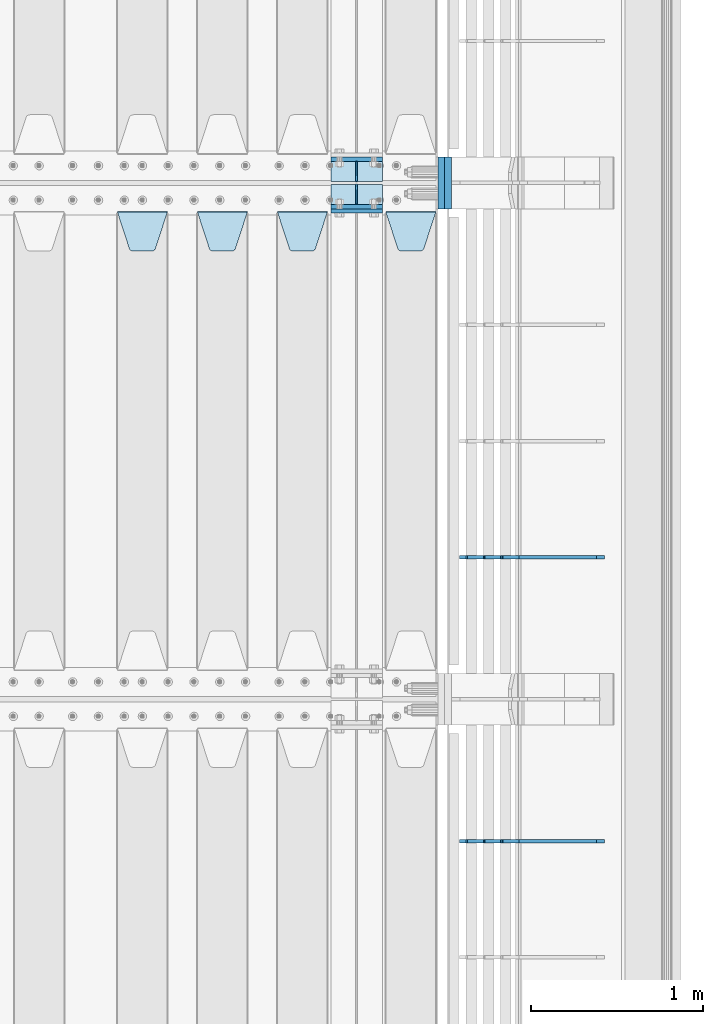
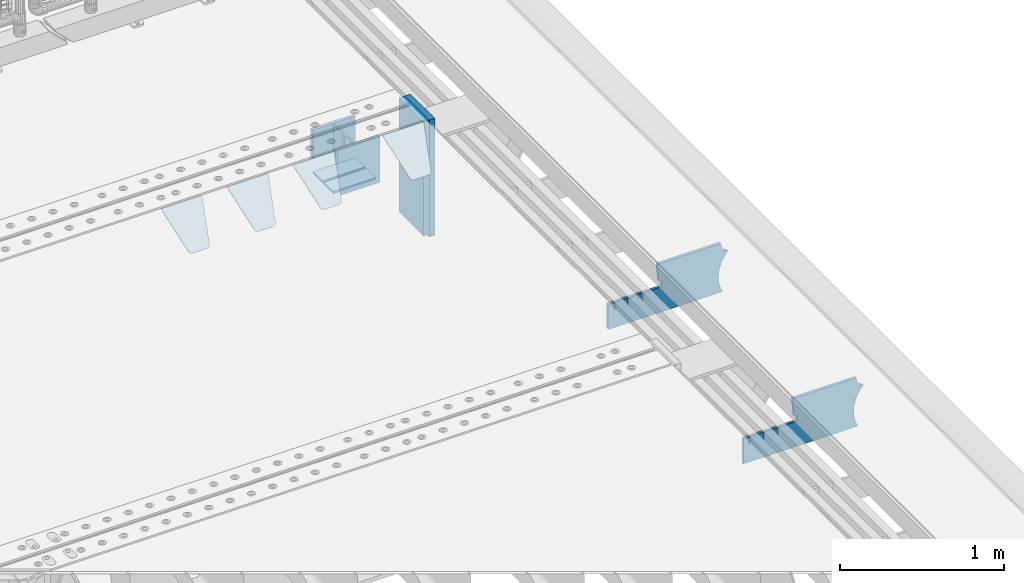
# One storey, part 239 of 257: 15 plates.
"""IFC2X3 building model written with IfcOpenShell, lengths in millimetres."""

from ifc_helpers import new_model, si_unit, frame, origin_with_axes, place, context, subcontext, project, spatial, faceted_brep, material, type_object, element, save


model = new_model("IFC2X3")

# Units and contexts
model_context = context("Model", 3, precision=1e-05, world=origin_with_axes())
body_context = subcontext(model_context, "Body", "Model", "MODEL_VIEW")
ifc_project = project(units=[si_unit("LENGTHUNIT", "METRE", prefix="MILLI"), si_unit("AREAUNIT", "SQUARE_METRE"), si_unit("VOLUMEUNIT", "CUBIC_METRE"), si_unit("MASSUNIT", "GRAM", prefix="KILO"), si_unit("TIMEUNIT", "SECOND"), si_unit("PLANEANGLEUNIT", "RADIAN"), si_unit("SOLIDANGLEUNIT", "STERADIAN"), si_unit("THERMODYNAMICTEMPERATUREUNIT", "DEGREE_CELSIUS"), si_unit("LUMINOUSINTENSITYUNIT", "LUMEN")], contexts=[model_context])

# Site, building, storey
site_placement = place(None, origin_with_axes())
site = spatial("IfcSite", under=ifc_project, at=site_placement, CompositionType="ELEMENT")
building_placement = place(site_placement, origin_with_axes())
building = spatial("IfcBuilding", under=site, at=building_placement, Name="Standard", CompositionType="ELEMENT")
storey_placement = place(building_placement, origin_with_axes())
storey = spatial("IfcBuildingStorey", under=building, at=storey_placement, Name="Undefined", CompositionType="ELEMENT", Elevation=0.0)

# Plates
ifc_material_1 = material(Name="STEEL/S355N")
plate_type_1 = type_object("IfcPlateType", PredefinedType="NOTDEFINED")
for number, where, z_axis, x_axis in (
    (1, (58645.0, 9137.49999999999, -339.999999999993), (0.0, 0.0, 1.0), (1.0, 0.0, 0.0)),
    (2, (58645.0, 8862.49999999999, -339.999999999993), (0.0, 0.0, 1.0), (1.0, 0.0, 0.0)),
):
    element("IfcPlate", number, at=place(storey_placement, frame(where, z_axis=z_axis, x_axis=x_axis)), inside=storey, type_object=plate_type_1, material=ifc_material_1, context=body_context, shape_type="Brep", body=[
        faceted_brep([(0.0, -12.5, 0.0), (0.0, -12.5, 310.0), (0.0, 12.5, 310.0), (0.0, 12.5, 0.0), (300.0, -12.5, 310.0), (300.0, 12.5, 310.0), (300.0, -12.5, 0.0), (300.0, 12.5, 0.0)], [[[0, 1, 2, 3]], [[1, 4, 5, 2]], [[4, 6, 7, 5]], [[6, 0, 3, 7]], [[5, 7, 3, 2]], [[6, 4, 1, 0]]]),
    ])
plate_1_placement = place(storey_placement, frame((58645.0, 8837.5, -340.000000000044), z_axis=(0.0, 0.0, 1.0), x_axis=(1.0, 0.0, 0.0)))
element("IfcPlate", 3, at=plate_1_placement, inside=storey, type_object=plate_type_1, material=ifc_material_1, context=body_context, shape_type="Brep", body=[
    faceted_brep([(0.0, -12.5, 0.0), (0.0, -12.5, 340.0), (0.0, 12.5, 340.0), (0.0, 12.5, 0.0), (300.0, -12.5, 340.0), (300.0, 12.5, 340.0), (300.0, -12.5, 0.0), (300.0, 12.5, 0.0)], [[[0, 1, 2, 3]], [[1, 4, 5, 2]], [[4, 6, 7, 5]], [[6, 0, 3, 7]], [[5, 7, 3, 2]], [[6, 4, 1, 0]]]),
])
plate_type_2 = type_object("IfcPlateType", PredefinedType="NOTDEFINED")
for number, where, z_axis, x_axis in (
    (4, (58645.0, 8991.99999999999, -342.999999999993), (0.0, -1.0, 0.0), (1.0, 0.0, 0.0)),
    (5, (58645.0, 9007.99999999999, -342.999999999993), (0.0, 1.0, 0.0), (1.0, 0.0, 0.0)),
):
    element("IfcPlate", number, at=place(storey_placement, frame(where, z_axis=z_axis, x_axis=x_axis)), inside=storey, type_object=plate_type_2, material=ifc_material_1, context=body_context, shape_type="Brep", body=[
        faceted_brep([(0.0, -7.0, 0.0), (0.0, -7.0, 117.0), (0.0, 7.0, 117.0), (0.0, 7.0, 0.0), (300.0, -7.0, 117.0), (300.0, 7.0, 117.0), (300.0, -7.0, 0.0), (300.0, 7.0, 0.0)], [[[0, 1, 2, 3]], [[1, 4, 5, 2]], [[4, 6, 7, 5]], [[6, 0, 3, 7]], [[5, 7, 3, 2]], [[6, 4, 1, 0]]]),
    ])
plate_type_3 = type_object("IfcPlateType", PredefinedType="NOTDEFINED")
for number, where, z_axis, x_axis in (
    (6, (58795.0, 9007.99999999999, -29.999999999993), (0.0, 0.0, -1.0), (0.0, 1.0, 0.0)),
    (7, (58795.0, 8991.99999999999, -29.999999999993), (0.0, 0.0, -1.0), (0.0, -1.0, 0.0)),
):
    element("IfcPlate", number, at=place(storey_placement, frame(where, z_axis=z_axis, x_axis=x_axis)), inside=storey, type_object=plate_type_3, material=ifc_material_1, context=body_context, shape_type="Brep", body=[
        faceted_brep([(0.0, -5.0, 30.0), (0.0, -5.0, 306.0), (0.0, 5.0, 306.0), (0.0, 5.0, 30.0), (117.0, -5.0, 306.0), (117.0, 5.0, 306.0), (117.0, -5.0, 0.0), (117.0, 5.0, 0.0), (30.0, -5.0, 0.0), (30.0, 5.0, 0.0), (24.7905546699922, -5.0, 0.455767409633758), (24.7905546699922, 5.0, 0.455767409633758), (19.7393957002296, -5.0, 1.80922137642275), (19.7393957002296, 5.0, 1.80922137642275), (15.0, -5.0, 4.01923788646684), (15.0, 5.0, 4.01923788646684), (10.7163717094036, -5.0, 7.01866670643066), (10.7163717094036, 5.0, 7.01866670643066), (7.01866670643085, -5.0, 10.7163717094038), (7.01866670643085, 5.0, 10.7163717094038), (4.01923788646673, -5.0, 15.0), (4.01923788646673, 5.0, 15.0), (1.80922137642301, -5.0, 19.7393957002299), (1.80922137642301, 5.0, 19.7393957002299), (0.455767409634063, -5.0, 24.7905546699921), (0.455767409634063, 5.0, 24.7905546699921)], [[[0, 1, 2, 3]], [[1, 4, 5, 2]], [[4, 6, 7, 5]], [[6, 8, 9, 7]], [[8, 10, 11, 9]], [[10, 12, 13, 11]], [[12, 14, 15, 13]], [[14, 16, 17, 15]], [[16, 18, 19, 17]], [[18, 20, 21, 19]], [[20, 22, 23, 21]], [[22, 24, 25, 23]], [[24, 0, 3, 25]], [[5, 7, 9, 11, 13, 15, 17, 19, 21, 23, 25, 3, 2]], [[24, 22, 20, 18, 16, 14, 12, 10, 8, 6, 4, 1, 0]]]),
    ])
plate_type_4 = type_object("IfcPlateType", PredefinedType="NOTDEFINED")
plate_2_placement = place(storey_placement, frame((58965.0, 8831.76776695594, -1.767766952965), z_axis=(0.0, -0.707106781186548, -0.707106781186547), x_axis=(1.0, 0.0, 0.0)))
element("IfcPlate", 8, at=plate_2_placement, inside=storey, type_object=plate_type_4, material=ifc_material_1, context=body_context, shape_type="Brep", body=[
    faceted_brep([(0.0, -2.5, 0.0), (69.345504679477, -2.50000000000091, 300.17173142483), (69.345504679477, 2.5, 300.171731424831), (0.0, 2.5, 0.0), (70.927406119954, -2.50000000000091, 304.8974424154), (70.927406119954, 2.5, 304.8974424154), (73.3818627772271, -2.50000000000091, 309.234538108527), (73.3818627772271, 2.49999999999909, 309.234538108527), (76.6187032999587, -2.5, 313.023683126103), (76.6187032999587, 2.5, 313.023683126103), (80.5190132705029, -2.5, 316.125672595372), (80.5190132705029, 2.5, 316.125672595371), (84.9395038596849, -2.5, 318.426546230476), (84.9395038596849, 2.5, 318.426546230477), (89.7177759439219, -2.5, 319.841774983275), (89.7177759439219, 2.5, 319.841774983275), (94.6782862926484, -2.5, 320.319366455079), (94.6782862926484, 2.5, 320.319366455079), (195.321713707352, -2.5, 320.319366455079), (195.321713707352, 2.5, 320.319366455079), (200.282224056078, -2.5, 319.841774983275), (200.282224056078, 2.49999999999909, 319.841774983275), (205.060496140315, -2.5, 318.426546230476), (205.060496140315, 2.49999999999909, 318.426546230475), (209.480986729497, -2.5, 316.125672595371), (209.480986729497, 2.5, 316.125672595371), (213.381296700041, -2.50000000000091, 313.023683126102), (213.381296700041, 2.5, 313.023683126103), (216.618137222766, -2.50000000000091, 309.234538108527), (216.618137222766, 2.5, 309.234538108527), (219.072593880039, -2.5, 304.897442415399), (219.072593880039, 2.5, 304.897442415399), (220.654495320523, -2.50000000000091, 300.17173142483), (220.654495320523, 2.5, 300.171731424831), (290.0, -2.50000000000091, 0.0), (290.0, 2.5, 9.09494701772928e-13)], [[[0, 1, 2, 3]], [[1, 4, 5, 2]], [[4, 6, 7, 5]], [[6, 8, 9, 7]], [[8, 10, 11, 9]], [[10, 12, 13, 11]], [[12, 14, 15, 13]], [[14, 16, 17, 15]], [[16, 18, 19, 17]], [[18, 20, 21, 19]], [[20, 22, 23, 21]], [[22, 24, 25, 23]], [[24, 26, 27, 25]], [[26, 28, 29, 27]], [[28, 30, 31, 29]], [[30, 32, 33, 31]], [[32, 34, 35, 33]], [[34, 0, 3, 35]], [[5, 7, 9, 11, 13, 15, 17, 19, 21, 23, 25, 27, 29, 31, 33, 35, 3, 2]], [[34, 32, 30, 28, 26, 24, 22, 20, 18, 16, 14, 12, 10, 8, 6, 4, 1, 0]]]),
])
plate_3_placement = place(storey_placement, frame((58335.0, 8831.76776695594, -1.767766952965), z_axis=(0.0, -0.707106781186548, -0.707106781186547), x_axis=(1.0, 0.0, 0.0)))
element("IfcPlate", 9, at=plate_3_placement, inside=storey, type_object=plate_type_4, material=ifc_material_1, context=body_context, shape_type="Brep", body=[
    faceted_brep([(0.0, -2.5, 0.0), (69.345504679477, -2.50000000000091, 300.17173142483), (69.345504679477, 2.5, 300.171731424831), (0.0, 2.5, 0.0), (70.927406119954, -2.50000000000091, 304.8974424154), (70.927406119954, 2.5, 304.8974424154), (73.3818627772271, -2.50000000000091, 309.234538108527), (73.3818627772271, 2.49999999999909, 309.234538108527), (76.6187032999587, -2.5, 313.023683126103), (76.6187032999587, 2.5, 313.023683126103), (80.5190132705029, -2.5, 316.125672595372), (80.5190132705029, 2.5, 316.125672595371), (84.9395038596849, -2.5, 318.426546230476), (84.9395038596849, 2.5, 318.426546230477), (89.7177759439219, -2.5, 319.841774983275), (89.7177759439219, 2.5, 319.841774983275), (94.6782862926484, -2.5, 320.319366455079), (94.6782862926484, 2.5, 320.319366455079), (195.321713707352, -2.5, 320.319366455079), (195.321713707352, 2.5, 320.319366455079), (200.282224056078, -2.5, 319.841774983275), (200.282224056078, 2.49999999999909, 319.841774983275), (205.060496140315, -2.5, 318.426546230476), (205.060496140315, 2.49999999999909, 318.426546230475), (209.480986729497, -2.5, 316.125672595371), (209.480986729497, 2.5, 316.125672595371), (213.381296700041, -2.50000000000091, 313.023683126102), (213.381296700041, 2.5, 313.023683126103), (216.618137222766, -2.50000000000091, 309.234538108527), (216.618137222766, 2.5, 309.234538108527), (219.072593880039, -2.5, 304.897442415399), (219.072593880039, 2.5, 304.897442415399), (220.654495320523, -2.50000000000091, 300.17173142483), (220.654495320523, 2.5, 300.171731424831), (290.0, -2.50000000000091, 0.0), (290.0, 2.5, 9.09494701772928e-13)], [[[0, 1, 2, 3]], [[1, 4, 5, 2]], [[4, 6, 7, 5]], [[6, 8, 9, 7]], [[8, 10, 11, 9]], [[10, 12, 13, 11]], [[12, 14, 15, 13]], [[14, 16, 17, 15]], [[16, 18, 19, 17]], [[18, 20, 21, 19]], [[20, 22, 23, 21]], [[22, 24, 25, 23]], [[24, 26, 27, 25]], [[26, 28, 29, 27]], [[28, 30, 31, 29]], [[30, 32, 33, 31]], [[32, 34, 35, 33]], [[34, 0, 3, 35]], [[5, 7, 9, 11, 13, 15, 17, 19, 21, 23, 25, 27, 29, 31, 33, 35, 3, 2]], [[34, 32, 30, 28, 26, 24, 22, 20, 18, 16, 14, 12, 10, 8, 6, 4, 1, 0]]]),
])
plate_4_placement = place(storey_placement, frame((57870.0, 8831.76776695594, -1.767766952965), z_axis=(0.0, -0.707106781186548, -0.707106781186547), x_axis=(1.0, 0.0, 0.0)))
element("IfcPlate", 10, at=plate_4_placement, inside=storey, type_object=plate_type_4, material=ifc_material_1, context=body_context, shape_type="Brep", body=[
    faceted_brep([(0.0, -2.5, 0.0), (69.345504679477, -2.50000000000091, 300.17173142483), (69.345504679477, 2.5, 300.171731424831), (0.0, 2.5, 0.0), (70.927406119954, -2.50000000000091, 304.8974424154), (70.927406119954, 2.5, 304.8974424154), (73.3818627772271, -2.50000000000091, 309.234538108527), (73.3818627772271, 2.49999999999909, 309.234538108527), (76.6187032999587, -2.5, 313.023683126103), (76.6187032999587, 2.5, 313.023683126103), (80.5190132705029, -2.5, 316.125672595372), (80.5190132705029, 2.5, 316.125672595371), (84.9395038596849, -2.5, 318.426546230476), (84.9395038596849, 2.5, 318.426546230477), (89.7177759439219, -2.5, 319.841774983275), (89.7177759439219, 2.5, 319.841774983275), (94.6782862926484, -2.5, 320.319366455079), (94.6782862926484, 2.5, 320.319366455079), (195.321713707352, -2.5, 320.319366455079), (195.321713707352, 2.5, 320.319366455079), (200.282224056078, -2.5, 319.841774983275), (200.282224056078, 2.49999999999909, 319.841774983275), (205.060496140315, -2.5, 318.426546230476), (205.060496140315, 2.49999999999909, 318.426546230475), (209.480986729497, -2.5, 316.125672595371), (209.480986729497, 2.5, 316.125672595371), (213.381296700041, -2.50000000000091, 313.023683126102), (213.381296700041, 2.5, 313.023683126103), (216.618137222766, -2.50000000000091, 309.234538108527), (216.618137222766, 2.5, 309.234538108527), (219.072593880039, -2.5, 304.897442415399), (219.072593880039, 2.5, 304.897442415399), (220.654495320523, -2.50000000000091, 300.17173142483), (220.654495320523, 2.5, 300.171731424831), (290.0, -2.50000000000091, 0.0), (290.0, 2.5, 9.09494701772928e-13)], [[[0, 1, 2, 3]], [[1, 4, 5, 2]], [[4, 6, 7, 5]], [[6, 8, 9, 7]], [[8, 10, 11, 9]], [[10, 12, 13, 11]], [[12, 14, 15, 13]], [[14, 16, 17, 15]], [[16, 18, 19, 17]], [[18, 20, 21, 19]], [[20, 22, 23, 21]], [[22, 24, 25, 23]], [[24, 26, 27, 25]], [[26, 28, 29, 27]], [[28, 30, 31, 29]], [[30, 32, 33, 31]], [[32, 34, 35, 33]], [[34, 0, 3, 35]], [[5, 7, 9, 11, 13, 15, 17, 19, 21, 23, 25, 27, 29, 31, 33, 35, 3, 2]], [[34, 32, 30, 28, 26, 24, 22, 20, 18, 16, 14, 12, 10, 8, 6, 4, 1, 0]]]),
])
plate_5_placement = place(storey_placement, frame((57405.0, 8831.76776695594, -1.767766952965), z_axis=(0.0, -0.707106781186548, -0.707106781186547), x_axis=(1.0, 0.0, 0.0)))
element("IfcPlate", 11, at=plate_5_placement, inside=storey, type_object=plate_type_4, material=ifc_material_1, context=body_context, shape_type="Brep", body=[
    faceted_brep([(0.0, -2.5, 0.0), (69.345504679477, -2.50000000000091, 300.17173142483), (69.345504679477, 2.5, 300.171731424831), (0.0, 2.5, 0.0), (70.927406119954, -2.50000000000091, 304.8974424154), (70.927406119954, 2.5, 304.8974424154), (73.3818627772271, -2.50000000000091, 309.234538108527), (73.3818627772271, 2.49999999999909, 309.234538108527), (76.6187032999587, -2.5, 313.023683126103), (76.6187032999587, 2.5, 313.023683126103), (80.5190132705029, -2.5, 316.125672595372), (80.5190132705029, 2.5, 316.125672595371), (84.9395038596849, -2.5, 318.426546230476), (84.9395038596849, 2.5, 318.426546230477), (89.7177759439219, -2.5, 319.841774983275), (89.7177759439219, 2.5, 319.841774983275), (94.6782862926484, -2.5, 320.319366455079), (94.6782862926484, 2.5, 320.319366455079), (195.321713707352, -2.5, 320.319366455079), (195.321713707352, 2.5, 320.319366455079), (200.282224056078, -2.5, 319.841774983275), (200.282224056078, 2.49999999999909, 319.841774983275), (205.060496140315, -2.5, 318.426546230476), (205.060496140315, 2.49999999999909, 318.426546230475), (209.480986729497, -2.5, 316.125672595371), (209.480986729497, 2.5, 316.125672595371), (213.381296700041, -2.50000000000091, 313.023683126102), (213.381296700041, 2.5, 313.023683126103), (216.618137222766, -2.50000000000091, 309.234538108527), (216.618137222766, 2.5, 309.234538108527), (219.072593880039, -2.5, 304.897442415399), (219.072593880039, 2.5, 304.897442415399), (220.654495320523, -2.50000000000091, 300.17173142483), (220.654495320523, 2.5, 300.171731424831), (290.0, -2.50000000000091, 0.0), (290.0, 2.5, 9.09494701772928e-13)], [[[0, 1, 2, 3]], [[1, 4, 5, 2]], [[4, 6, 7, 5]], [[6, 8, 9, 7]], [[8, 10, 11, 9]], [[10, 12, 13, 11]], [[12, 14, 15, 13]], [[14, 16, 17, 15]], [[16, 18, 19, 17]], [[18, 20, 21, 19]], [[20, 22, 23, 21]], [[22, 24, 25, 23]], [[24, 26, 27, 25]], [[26, 28, 29, 27]], [[28, 30, 31, 29]], [[30, 32, 33, 31]], [[32, 34, 35, 33]], [[34, 0, 3, 35]], [[5, 7, 9, 11, 13, 15, 17, 19, 21, 23, 25, 27, 29, 31, 33, 35, 3, 2]], [[34, 32, 30, 28, 26, 24, 22, 20, 18, 16, 14, 12, 10, 8, 6, 4, 1, 0]]]),
])
ifc_material_2 = material()
plate_type_5 = type_object("IfcPlateType", PredefinedType="NOTDEFINED")
plate_6_placement = place(storey_placement, frame((59287.0, 9150.0, -870.0), z_axis=(0.0, 0.0, 1.0), x_axis=(0.0, -1.0, 0.0)))
element("IfcPlate", 12, at=plate_6_placement, inside=storey, type_object=plate_type_5, material=ifc_material_2, context=body_context, shape_type="Brep", body=[
    faceted_brep([(0.0, -20.0, 0.0), (0.0, -20.0, 850.0), (0.0, 20.0, 850.0), (0.0, 20.0, 0.0), (300.0, -20.0, 850.0), (300.0, 20.0, 850.0), (300.0, -20.0, -1.81898940354586e-12), (300.0, 20.0, -1.81898940354586e-12)], [[[0, 1, 2, 3]], [[1, 4, 5, 2]], [[4, 6, 7, 5]], [[6, 0, 3, 7]], [[5, 7, 3, 2]], [[6, 4, 1, 0]]]),
])
plate_7_placement = place(storey_placement, frame((59326.9988298906, 9150.0, -889.999999999995), z_axis=(0.0, 0.0, 1.0), x_axis=(0.0, -1.0, 0.0)))
element("IfcPlate", 13, at=plate_7_placement, inside=storey, type_object=plate_type_5, material=ifc_material_2, context=body_context, shape_type="Brep", body=[
    faceted_brep([(0.0, -20.0, 0.0), (0.0, -20.0, 870.0), (0.0, 20.0, 870.0), (0.0, 20.0, 0.0), (300.0, -20.0, 870.0), (300.0, 20.0, 870.0), (300.0, -20.0, -1.81898940354586e-12), (300.0, 20.0, -1.81898940354586e-12)], [[[0, 1, 2, 3]], [[1, 4, 5, 2]], [[4, 6, 7, 5]], [[6, 0, 3, 7]], [[5, 7, 3, 2]], [[6, 4, 1, 0]]]),
])
plate_type_6 = type_object("IfcPlateType", PredefinedType="NOTDEFINED")
plate_8_placement = place(storey_placement, frame((60232.9182339676, 5174.99928283691, -374.002067436517), z_axis=(0.0, 0.0, 1.0), x_axis=(-1.0, 0.0, 0.0)))
element("IfcPlate", 14, at=plate_8_placement, inside=storey, type_object=plate_type_6, material=ifc_material_1, context=body_context, shape_type="Brep", body=[
    faceted_brep([(801.919404066546, -10.0, 188.0), (801.919404066546, 10.0, 188.0), (801.919404066546, 10.0, 132.002067436952), (801.919404066546, -10.0, 132.002067436952), (793.919404066546, 10.0, 132.002067436952), (793.919404066546, -10.0, 132.002067436952), (793.919404066546, 10.0, 180.002067436952), (793.919404066546, -10.0, 180.002067436952), (793.52785619691, 10.0, 182.474203391951), (793.52785619691, -10.0, 182.474203391951), (792.391540021548, 10.0, 184.704349455291), (792.391540021548, -10.0, 184.704349455291), (790.621686084887, 10.0, 186.474203391951), (790.621686084887, -10.0, 186.474203391951), (788.391540021548, 10.0, 187.610519567313), (788.391540021548, -10.0, 187.610519567313), (785.919404066546, -10.0, 188.002067436952), (785.919404066546, 10.0, 188.0), (841.0, -10.0, 188.0), (841.0, -10.0, 0.0), (841.0, 10.0, 0.0), (841.0, 10.0, 188.0), (33.3619566735943, -10.0, 0.0), (33.3619566735943, 10.0, 0.0), (36.2350612208102, -10.0, 4.68848050267013), (36.2350612208102, 10.0, 4.68848050267013), (51.4877592159319, -10.0, 41.5117508652784), (51.4877592159319, 10.0, 41.5117508652784), (60.7922425881334, -10.0, 80.2677133162964), (60.7922425881334, 10.0, 80.2677133162964), (63.9194040769653, -10.0, 120.002067436515), (63.9194040769653, 10.0, 120.002067436515), (60.7922425881334, -10.0, 159.736421556734), (60.7922425881334, 10.0, 159.736421556734), (51.4877592159319, -10.0, 198.492384007752), (51.4877592159319, 10.0, 198.492384007752), (36.2350612208102, -10.0, 235.31565437036), (36.2350612208102, 10.0, 235.31565437036), (15.4097206482038, -10.0, 269.299521518803), (15.4097206482038, 10.0, 269.299521518803), (-3.35474438100209, -10.0, 291.269887256574), (-3.35474438100209, 10.0, 291.269887256574), (-2.36881039375294, -10.0000000000001, 291.426043859339), (-2.36881039375294, 10.0, 291.426043859339), (17.1449676604752, -10.0000000000001, 301.368810393754), (17.1449676604752, 10.0, 301.368810393754), (32.6311896062471, -10.0000000000001, 316.855032339527), (32.6311896062471, 10.0, 316.855032339527), (42.573956140659, -10.0000000000001, 336.368810393754), (42.573956140659, 10.0, 336.368810393754), (46.0, -10.0000000000001, 358.0), (46.0, 10.0, 358.0), (45.0495205499174, -10.0, 364.001091067617), (45.0495205499174, 10.0, 364.001091067617), (495.040008544922, -10.0, 364.010009765625), (495.040008544922, 10.0, 364.010009765625), (483.600036621094, -10.0, 233.759994506836), (483.600036621094, 10.0, 233.759994506836), (472.0, -10.0, 233.759994506836), (472.0, 10.0, 233.759994506836), (468.909830056247, -10.0, 233.270559669787), (468.909830056247, 10.0, 233.270559669787), (466.122147477072, -10.0, 231.850164450585), (466.122147477072, 10.0, 231.850164450585), (463.909830056247, -10.0, 229.637847029761), (463.909830056247, 10.0, 229.637847029761), (462.489434837051, -10.0, 226.850164450585), (462.489434837051, 10.0, 226.850164450585), (462.0, -10.0, 223.759994506836), (462.0, 10.0, 223.759994506836), (462.0, -10.0, 198.0), (462.0, 10.0, 198.0), (462.489434837051, -10.0, 194.909830056251), (462.489434837051, 10.0, 194.909830056251), (463.909830056247, -10.0, 192.122147477075), (463.909830056247, 10.0, 192.122147477075), (466.122147477072, -10.0, 189.909830056251), (466.122147477072, 10.0, 189.909830056251), (468.909830056247, -10.0, 188.489434837048), (468.909830056247, 10.0, 188.489434837048), (472.0, -10.0, 188.0), (472.0, 10.0, 188.0), (585.919404066546, -10.0, 188.002067436952), (585.919404066546, 10.0, 188.0), (588.391540021548, -10.0, 187.610519567313), (588.391540021548, 10.0, 187.610519567313), (590.621686084887, -10.0, 186.474203391951), (590.621686084887, 10.0, 186.474203391951), (592.391540021548, -10.0, 184.704349455291), (592.391540021548, 10.0, 184.704349455291), (593.52785619691, -10.0, 182.474203391951), (593.52785619691, 10.0, 182.474203391951), (593.919404066546, -10.0, 180.002067436952), (593.919404066546, 10.0, 180.002067436952), (593.919404066546, -10.0, 132.002067436952), (593.919404066546, 10.0, 132.002067436952), (601.919404066546, -10.0, 132.002067436952), (601.919404066546, 10.0, 132.002067436952), (601.919404066546, -10.0, 188.0), (601.919404066546, 10.0, 188.0), (685.919404066546, -10.0, 188.002067436952), (685.919404066546, 10.0, 188.0), (688.391540021548, -9.99999999999977, 187.610519567313), (688.391540021548, 10.0, 187.610519567313), (690.621686084887, -9.99999999999977, 186.474203391951), (690.621686084887, 10.0, 186.474203391951), (692.391540021548, -9.99999999999977, 184.704349455291), (692.391540021548, 10.0, 184.704349455291), (693.52785619691, -9.99999999999977, 182.474203391951), (693.52785619691, 10.0, 182.474203391951), (693.919404066546, -9.99999999999977, 180.002067436952), (693.919404066546, 10.0, 180.002067436952), (693.919404066546, -9.99999999999977, 132.002067436952), (693.919404066546, 10.0, 132.002067436952), (701.919404066546, -9.99999999999977, 132.002067436952), (701.919404066546, 10.0, 132.002067436952), (701.919404066546, -10.0, 188.0), (701.919404066546, 10.0, 188.0)], [[[0, 1, 2, 3]], [[3, 2, 4, 5]], [[5, 4, 6, 7]], [[7, 6, 8, 9]], [[9, 8, 10, 11]], [[11, 10, 12, 13]], [[13, 12, 14, 15]], [[16, 15, 14, 17]], [[18, 19, 20, 21]], [[20, 19, 22, 23]], [[22, 24, 25, 23]], [[26, 27, 25, 24]], [[28, 29, 27, 26]], [[30, 31, 29, 28]], [[32, 33, 31, 30]], [[34, 35, 33, 32]], [[36, 37, 35, 34]], [[38, 39, 37, 36]], [[39, 38, 40, 41]], [[40, 42, 43, 41]], [[44, 45, 43, 42]], [[46, 47, 45, 44]], [[48, 49, 47, 46]], [[50, 51, 49, 48]], [[52, 53, 51, 50]], [[54, 55, 53, 52]], [[54, 56, 57, 55]], [[56, 58, 59, 57]], [[58, 60, 61, 59]], [[60, 62, 63, 61]], [[62, 64, 65, 63]], [[64, 66, 67, 65]], [[66, 68, 69, 67]], [[68, 70, 71, 69]], [[70, 72, 73, 71]], [[72, 74, 75, 73]], [[74, 76, 77, 75]], [[76, 78, 79, 77]], [[78, 80, 81, 79]], [[81, 80, 82, 83]], [[82, 84, 85, 83]], [[86, 87, 85, 84]], [[88, 89, 87, 86]], [[90, 91, 89, 88]], [[92, 93, 91, 90]], [[94, 95, 93, 92]], [[96, 97, 95, 94]], [[98, 99, 97, 96]], [[99, 98, 100, 101]], [[100, 102, 103, 101]], [[104, 105, 103, 102]], [[106, 107, 105, 104]], [[108, 109, 107, 106]], [[110, 111, 109, 108]], [[112, 113, 111, 110]], [[114, 115, 113, 112]], [[116, 117, 115, 114]], [[117, 116, 16, 17]], [[12, 10, 8, 6, 4, 2, 1, 21, 20, 23, 25, 27, 29, 31, 33, 35, 37, 39, 41, 43, 45, 47, 49, 51, 53, 55, 57, 59, 61, 63, 65, 67, 69, 71, 73, 75, 77, 79, 81, 83, 85, 87, 89, 91, 93, 95, 97, 99, 101, 103, 105, 107, 109, 111, 113, 115, 117, 17, 14]], [[18, 21, 1, 0]], [[116, 114, 112, 110, 108, 106, 104, 102, 100, 98, 96, 94, 92, 90, 88, 86, 84, 82, 80, 78, 76, 74, 72, 70, 68, 66, 64, 62, 60, 58, 56, 54, 52, 50, 48, 46, 44, 42, 40, 38, 36, 34, 32, 30, 28, 26, 24, 22, 19, 18, 0, 3, 5, 7, 9, 11, 13, 15, 16]]]),
])
plate_9_placement = place(storey_placement, frame((60232.9182339676, 6824.99928283691, -374.002067436517), z_axis=(0.0, 0.0, 1.0), x_axis=(-1.0, 0.0, 0.0)))
element("IfcPlate", 15, at=plate_9_placement, inside=storey, type_object=plate_type_6, material=ifc_material_1, context=body_context, shape_type="Brep", body=[
    faceted_brep([(801.919404066546, -10.0, 188.0), (801.919404066546, 10.0, 188.0), (801.919404066546, 10.0, 132.002067436952), (801.919404066546, -10.0, 132.002067436952), (793.919404066546, 10.0, 132.002067436952), (793.919404066546, -10.0, 132.002067436952), (793.919404066546, 10.0, 180.002067436952), (793.919404066546, -10.0, 180.002067436952), (793.52785619691, 10.0, 182.474203391951), (793.52785619691, -10.0, 182.474203391951), (792.391540021548, 10.0, 184.704349455291), (792.391540021548, -10.0, 184.704349455291), (790.621686084887, 10.0, 186.474203391951), (790.621686084887, -10.0, 186.474203391951), (788.391540021548, 10.0, 187.610519567313), (788.391540021548, -10.0, 187.610519567313), (785.919404066546, -10.0, 188.002067436952), (785.919404066546, 10.0, 188.0), (841.0, -10.0, 188.0), (841.0, -10.0, 0.0), (841.0, 10.0, 0.0), (841.0, 10.0, 188.0), (33.3619566735943, -10.0, 0.0), (33.3619566735943, 10.0, 0.0), (36.2350612208102, -10.0, 4.68848050267013), (36.2350612208102, 10.0, 4.68848050267013), (51.4877592159319, -10.0, 41.5117508652784), (51.4877592159319, 10.0, 41.5117508652784), (60.7922425881334, -10.0, 80.2677133162964), (60.7922425881334, 10.0, 80.2677133162964), (63.9194040769653, -10.0, 120.002067436515), (63.9194040769653, 10.0, 120.002067436515), (60.7922425881334, -10.0, 159.736421556734), (60.7922425881334, 10.0, 159.736421556734), (51.4877592159319, -10.0, 198.492384007752), (51.4877592159319, 10.0, 198.492384007752), (36.2350612208102, -10.0, 235.31565437036), (36.2350612208102, 10.0, 235.31565437036), (15.4097206482038, -10.0, 269.299521518803), (15.4097206482038, 10.0, 269.299521518803), (-3.35474438100209, -10.0, 291.269887256574), (-3.35474438100209, 10.0, 291.269887256574), (-2.36881039375294, -10.0000000000001, 291.426043859339), (-2.36881039375294, 10.0, 291.426043859339), (17.1449676604752, -10.0000000000001, 301.368810393754), (17.1449676604752, 10.0, 301.368810393754), (32.6311896062471, -10.0000000000001, 316.855032339527), (32.6311896062471, 10.0, 316.855032339527), (42.573956140659, -10.0000000000001, 336.368810393754), (42.573956140659, 10.0, 336.368810393754), (46.0, -10.0000000000001, 358.0), (46.0, 10.0, 358.0), (45.0495205499174, -10.0, 364.001091067617), (45.0495205499174, 10.0, 364.001091067617), (495.040008544922, -10.0, 364.010009765625), (495.040008544922, 10.0, 364.010009765625), (483.600036621094, -10.0, 233.759994506836), (483.600036621094, 10.0, 233.759994506836), (472.0, -10.0, 233.759994506836), (472.0, 10.0, 233.759994506836), (468.909830056247, -10.0, 233.270559669787), (468.909830056247, 10.0, 233.270559669787), (466.122147477072, -10.0, 231.850164450585), (466.122147477072, 10.0, 231.850164450585), (463.909830056247, -10.0, 229.637847029761), (463.909830056247, 10.0, 229.637847029761), (462.489434837051, -10.0, 226.850164450585), (462.489434837051, 10.0, 226.850164450585), (462.0, -10.0, 223.759994506836), (462.0, 10.0, 223.759994506836), (462.0, -10.0, 198.0), (462.0, 10.0, 198.0), (462.489434837051, -10.0, 194.909830056251), (462.489434837051, 10.0, 194.909830056251), (463.909830056247, -10.0, 192.122147477075), (463.909830056247, 10.0, 192.122147477075), (466.122147477072, -10.0, 189.909830056251), (466.122147477072, 10.0, 189.909830056251), (468.909830056247, -10.0, 188.489434837048), (468.909830056247, 10.0, 188.489434837048), (472.0, -10.0, 188.0), (472.0, 10.0, 188.0), (585.919404066546, -10.0, 188.002067436952), (585.919404066546, 10.0, 188.0), (588.391540021548, -10.0, 187.610519567313), (588.391540021548, 10.0, 187.610519567313), (590.621686084887, -10.0, 186.474203391951), (590.621686084887, 10.0, 186.474203391951), (592.391540021548, -10.0, 184.704349455291), (592.391540021548, 10.0, 184.704349455291), (593.52785619691, -10.0, 182.474203391951), (593.52785619691, 10.0, 182.474203391951), (593.919404066546, -10.0, 180.002067436952), (593.919404066546, 10.0, 180.002067436952), (593.919404066546, -10.0, 132.002067436952), (593.919404066546, 10.0, 132.002067436952), (601.919404066546, -10.0, 132.002067436952), (601.919404066546, 10.0, 132.002067436952), (601.919404066546, -10.0, 188.0), (601.919404066546, 10.0, 188.0), (685.919404066546, -10.0, 188.002067436952), (685.919404066546, 10.0, 188.0), (688.391540021548, -9.99999999999977, 187.610519567313), (688.391540021548, 10.0, 187.610519567313), (690.621686084887, -9.99999999999977, 186.474203391951), (690.621686084887, 10.0, 186.474203391951), (692.391540021548, -9.99999999999977, 184.704349455291), (692.391540021548, 10.0, 184.704349455291), (693.52785619691, -9.99999999999977, 182.474203391951), (693.52785619691, 10.0, 182.474203391951), (693.919404066546, -9.99999999999977, 180.002067436952), (693.919404066546, 10.0, 180.002067436952), (693.919404066546, -9.99999999999977, 132.002067436952), (693.919404066546, 10.0, 132.002067436952), (701.919404066546, -9.99999999999977, 132.002067436952), (701.919404066546, 10.0, 132.002067436952), (701.919404066546, -10.0, 188.0), (701.919404066546, 10.0, 188.0)], [[[0, 1, 2, 3]], [[3, 2, 4, 5]], [[5, 4, 6, 7]], [[7, 6, 8, 9]], [[9, 8, 10, 11]], [[11, 10, 12, 13]], [[13, 12, 14, 15]], [[16, 15, 14, 17]], [[18, 19, 20, 21]], [[20, 19, 22, 23]], [[22, 24, 25, 23]], [[26, 27, 25, 24]], [[28, 29, 27, 26]], [[30, 31, 29, 28]], [[32, 33, 31, 30]], [[34, 35, 33, 32]], [[36, 37, 35, 34]], [[38, 39, 37, 36]], [[39, 38, 40, 41]], [[40, 42, 43, 41]], [[44, 45, 43, 42]], [[46, 47, 45, 44]], [[48, 49, 47, 46]], [[50, 51, 49, 48]], [[52, 53, 51, 50]], [[54, 55, 53, 52]], [[54, 56, 57, 55]], [[56, 58, 59, 57]], [[58, 60, 61, 59]], [[60, 62, 63, 61]], [[62, 64, 65, 63]], [[64, 66, 67, 65]], [[66, 68, 69, 67]], [[68, 70, 71, 69]], [[70, 72, 73, 71]], [[72, 74, 75, 73]], [[74, 76, 77, 75]], [[76, 78, 79, 77]], [[78, 80, 81, 79]], [[81, 80, 82, 83]], [[82, 84, 85, 83]], [[86, 87, 85, 84]], [[88, 89, 87, 86]], [[90, 91, 89, 88]], [[92, 93, 91, 90]], [[94, 95, 93, 92]], [[96, 97, 95, 94]], [[98, 99, 97, 96]], [[99, 98, 100, 101]], [[100, 102, 103, 101]], [[104, 105, 103, 102]], [[106, 107, 105, 104]], [[108, 109, 107, 106]], [[110, 111, 109, 108]], [[112, 113, 111, 110]], [[114, 115, 113, 112]], [[116, 117, 115, 114]], [[117, 116, 16, 17]], [[12, 10, 8, 6, 4, 2, 1, 21, 20, 23, 25, 27, 29, 31, 33, 35, 37, 39, 41, 43, 45, 47, 49, 51, 53, 55, 57, 59, 61, 63, 65, 67, 69, 71, 73, 75, 77, 79, 81, 83, 85, 87, 89, 91, 93, 95, 97, 99, 101, 103, 105, 107, 109, 111, 113, 115, 117, 17, 14]], [[18, 21, 1, 0]], [[116, 114, 112, 110, 108, 106, 104, 102, 100, 98, 96, 94, 92, 90, 88, 86, 84, 82, 80, 78, 76, 74, 72, 70, 68, 66, 64, 62, 60, 58, 56, 54, 52, 50, 48, 46, 44, 42, 40, 38, 36, 34, 32, 30, 28, 26, 24, 22, 19, 18, 0, 3, 5, 7, 9, 11, 13, 15, 16]]]),
])

save(model, "model.ifc")
